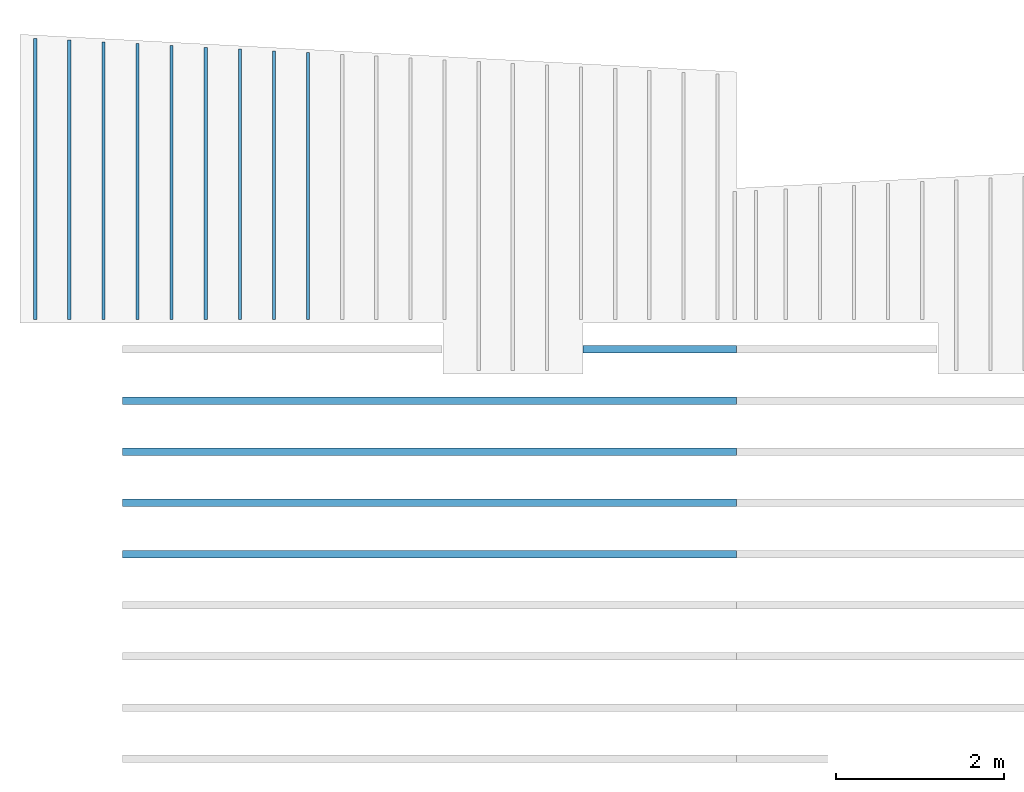
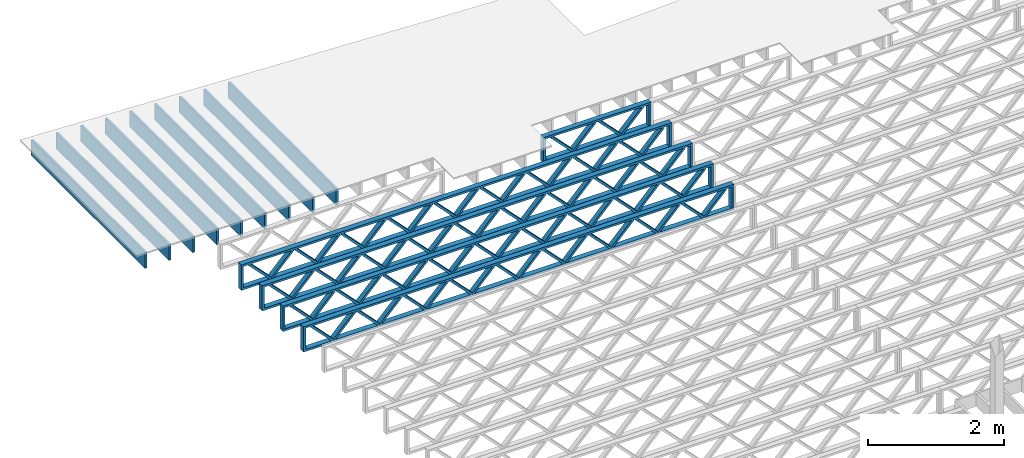
# One storey, part 3 of 12: 14 beams, 2 elements without a shape of their own.
"""IFC4 building model written with IfcOpenShell, lengths in feet."""

from ifc_helpers import new_model, entity, si_unit, converted_unit, derived_unit, direction, frame, frame_2d, origin, origin_2d_with_axis, place, context, subcontext, project, spatial, rectangle, extrude, source, transform, mapped, material, material_profile, profile_set, profile_usage, type_object, type_shapes, element, aggregate, save


model = new_model("IFC4")

# Units and contexts
model_context = context("Model", 3, precision=0.0001, world=origin(), true_north=direction((6.12303176911189e-17, 1.0)))
body_context = subcontext(model_context, "Body", "Model", "MODEL_VIEW")
ifc_project = project(units=[converted_unit("LENGTHUNIT", "FOOT", entity("IfcRatioMeasure", 0.3048), si_unit("LENGTHUNIT", "METRE"), dimensions=[1, 0, 0, 0, 0, 0, 0]), converted_unit("AREAUNIT", "SQUARE FOOT", entity("IfcRatioMeasure", 0.09290304), si_unit("AREAUNIT", "SQUARE_METRE"), dimensions=[2, 0, 0, 0, 0, 0, 0]), converted_unit("VOLUMEUNIT", "CUBIC FOOT", entity("IfcRatioMeasure", 0.028316846592), si_unit("VOLUMEUNIT", "CUBIC_METRE"), dimensions=[3, 0, 0, 0, 0, 0, 0]), converted_unit("PLANEANGLEUNIT", "DEGREE", entity("IfcRatioMeasure", 0.0174532925199433), si_unit("PLANEANGLEUNIT", "RADIAN"), dimensions=[0, 0, 0, 0, 0, 0, 0]), si_unit("MASSUNIT", "GRAM", prefix="KILO"), derived_unit("MASSDENSITYUNIT", [(si_unit("MASSUNIT", "GRAM", prefix="KILO"), 1), (si_unit("LENGTHUNIT", "METRE"), -3)]), derived_unit("MOMENTOFINERTIAUNIT", [(si_unit("LENGTHUNIT", "METRE"), 4)]), si_unit("TIMEUNIT", "SECOND"), si_unit("FREQUENCYUNIT", "HERTZ"), si_unit("THERMODYNAMICTEMPERATUREUNIT", "DEGREE_CELSIUS"), derived_unit("THERMALTRANSMITTANCEUNIT", [(si_unit("MASSUNIT", "GRAM", prefix="KILO"), 1), (si_unit("THERMODYNAMICTEMPERATUREUNIT", "KELVIN"), -1), (si_unit("TIMEUNIT", "SECOND"), -3)]), derived_unit("VOLUMETRICFLOWRATEUNIT", [(si_unit("LENGTHUNIT", "METRE"), 3), (si_unit("TIMEUNIT", "SECOND"), -1)]), si_unit("ELECTRICCURRENTUNIT", "AMPERE"), si_unit("ELECTRICVOLTAGEUNIT", "VOLT"), si_unit("POWERUNIT", "WATT"), si_unit("FORCEUNIT", "NEWTON"), si_unit("ILLUMINANCEUNIT", "LUX"), si_unit("LUMINOUSFLUXUNIT", "LUMEN"), si_unit("LUMINOUSINTENSITYUNIT", "CANDELA"), derived_unit("USERDEFINED", [(si_unit("MASSUNIT", "GRAM", prefix="KILO"), -1), (si_unit("LENGTHUNIT", "METRE"), -2), (si_unit("TIMEUNIT", "SECOND"), 3), (si_unit("LUMINOUSFLUXUNIT", "LUMEN"), 1)]), derived_unit("LINEARVELOCITYUNIT", [(si_unit("LENGTHUNIT", "METRE"), 1), (si_unit("TIMEUNIT", "SECOND"), -1)]), si_unit("PRESSUREUNIT", "PASCAL"), derived_unit("USERDEFINED", [(si_unit("LENGTHUNIT", "METRE"), -2), (si_unit("MASSUNIT", "GRAM", prefix="KILO"), 1), (si_unit("TIMEUNIT", "SECOND"), -2)]), derived_unit("LINEARFORCEUNIT", [(si_unit("MASSUNIT", "GRAM", prefix="KILO"), 1), (si_unit("LENGTHUNIT", "METRE"), 1), (si_unit("TIMEUNIT", "SECOND"), -2), (si_unit("LENGTHUNIT", "METRE"), -1)]), derived_unit("PLANARFORCEUNIT", [(si_unit("MASSUNIT", "GRAM", prefix="KILO"), 1), (si_unit("LENGTHUNIT", "METRE"), 1), (si_unit("TIMEUNIT", "SECOND"), -2), (si_unit("LENGTHUNIT", "METRE"), -2)])], contexts=[model_context])

# Site, building, storey
site_placement = place(None, origin())
site = spatial("IfcSite", under=ifc_project, at=site_placement, CompositionType="ELEMENT")
building_placement = place(site_placement, origin())
building = spatial("IfcBuilding", under=site, at=building_placement, CompositionType="ELEMENT")
storey_placement = place(building_placement, frame((0.0, 0.0, 21.46875)))
storey = spatial("IfcBuildingStorey", under=building, at=storey_placement, Name="3RD FLOOR", CompositionType="ELEMENT", Elevation=21.46875)

# Assembly, beams
assembly_1_placement = place(storey_placement, origin())
assembly_1 = element("IfcElementAssembly", 1, at=assembly_1_placement, inside=storey, Name="Structural Beam System:Structural Framing System", ObjectType="Structural Beam System:Structural Framing System", AssemblyPlace="NOTDEFINED", PredefinedType="BEAM_GRID")
ifc_material_1 = material(Name="WOOD TRUSS", Category="Materials")
ifc_material_profile_1 = material_profile(ifc_material_1, rectangle(XDim=1.73473973950632, YDim=0.125, at=frame_2d((-1.11022302462516e-16, 8.32667268468867e-17), x_axis=(1.0, 0.0))))
ifc_material_profile_2 = material_profile(ifc_material_1, rectangle(XDim=1.73473973950633, YDim=0.125, at=frame_2d((-1.11022302462516e-16, 8.32667268468867e-17), x_axis=(1.0, 0.0))))
ifc_material_profile_3 = material_profile(ifc_material_1, rectangle(XDim=1.73473973950632, YDim=0.125, at=frame_2d((-5.55111512312578e-17, 1.38777878078145e-16), x_axis=(1.0, 0.0))))
ifc_material_profile_4 = material_profile(ifc_material_1, rectangle(XDim=1.73473973950633, YDim=0.125, at=frame_2d((-1.11022302462516e-16, 8.32667268468867e-17), x_axis=(1.0, 0.0))))
ifc_material_profile_5 = material_profile(ifc_material_1, rectangle(XDim=1.73473973950632, YDim=0.125, at=frame_2d((-1.11022302462516e-16, 8.32667268468867e-17), x_axis=(1.0, 0.0))))
ifc_material_profile_6 = material_profile(ifc_material_1, rectangle(XDim=1.73473973950633, YDim=0.125, at=frame_2d((-2.77555756156289e-16, 3.05311331771918e-16), x_axis=(1.0, 0.0))))
ifc_material_profile_7 = material_profile(ifc_material_1, rectangle(XDim=1.73473973950632, YDim=0.124999999999999, at=frame_2d((-3.88578058618805e-16, -2.4980018054066e-16), x_axis=(1.0, 0.0))))
ifc_material_profile_8 = material_profile(ifc_material_1, rectangle(XDim=1.73473973950633, YDim=0.125, at=frame_2d((2.77555756156289e-16, -3.05311331771918e-16), x_axis=(1.0, 0.0))))
ifc_material_profile_9 = material_profile(ifc_material_1, rectangle(XDim=1.73473973950632, YDim=0.124999999999999, at=frame_2d((-1.11022302462516e-16, 8.32667268468867e-17), x_axis=(1.0, 0.0))))
ifc_material_profile_10 = material_profile(ifc_material_1, rectangle(XDim=1.73473973950633, YDim=0.125, at=origin_2d_with_axis()))
ifc_material_profile_11 = material_profile(ifc_material_1, rectangle(XDim=0.124999999999982, YDim=0.291666666666668, at=origin_2d_with_axis()))
ifc_material_profile_12 = material_profile(ifc_material_1, rectangle(XDim=0.124999999999932, YDim=0.291666666666664, at=origin_2d_with_axis()))
ifc_material_profile_13 = material_profile(ifc_material_1, rectangle(XDim=1.25000000000002, YDim=0.29166666666667, at=origin_2d_with_axis()))
ifc_material_profile_14 = material_profile(ifc_material_1, rectangle(XDim=1.25000000000004, YDim=0.291666666666667, at=origin_2d_with_axis()))
ifc_profile_set_1 = profile_set([ifc_material_profile_1, ifc_material_profile_2, ifc_material_profile_3, ifc_material_profile_4, ifc_material_profile_5, ifc_material_profile_6, ifc_material_profile_7, ifc_material_profile_8, ifc_material_profile_9, ifc_material_profile_10, ifc_material_profile_11, ifc_material_profile_12, ifc_material_profile_13, ifc_material_profile_14])
ifc_profile_usage_1 = profile_usage(ifc_profile_set_1, cardinal=8)
beam_type_1 = type_object("IfcBeamType", PredefinedType="BEAM", material=ifc_profile_set_1)
shared_shape_1 = source(origin(), body_context, "Body", "SweptSolid", [
    extrude(rectangle(XDim=1.73473973950632, YDim=0.125, at=frame_2d((0.0, 1.66533453693773e-16), x_axis=(1.0, 0.0))), frame((1.95847576769603, -0.145833333333334, 0.0), z_axis=(0.0, 1.0, 0.0), x_axis=(0.693383046997606, 0.0, 0.720569184836762)), (0.0, 0.0, 1.0), 0.291666666666667),
    extrude(rectangle(XDim=1.73473973950633, YDim=0.125, at=frame_2d((-5.55111512312578e-17, 8.32667268468867e-17), x_axis=(1.0, 0.0))), frame((0.708189894022761, -0.145833333333334, 0.0), z_axis=(0.0, 1.0, 0.0), x_axis=(0.69338304699761, 0.0, -0.720569184836758)), (0.0, 0.0, 1.0), 0.291666666666667),
    extrude(rectangle(XDim=1.73473973950632, YDim=0.125, at=frame_2d((0.0, 1.66533453693773e-16), x_axis=(1.0, 0.0))), frame((-0.708189894022106, -0.145833333333334, 0.0), z_axis=(0.0, 1.0, 0.0), x_axis=(0.693383046997606, 0.0, 0.720569184836762)), (0.0, 0.0, 1.0), 0.291666666666667),
    extrude(rectangle(XDim=1.73473973950633, YDim=0.125, at=frame_2d((-2.22044604925031e-16, 2.22044604925031e-16), x_axis=(1.0, 0.0))), frame((-1.95847576769538, -0.145833333333334, 0.0), z_axis=(0.0, 1.0, 0.0), x_axis=(0.69338304699761, 0.0, -0.720569184836758)), (0.0, 0.0, 1.0), 0.291666666666666),
    extrude(rectangle(XDim=0.124999999999982, YDim=0.291666666666668, at=origin_2d_with_axis()), frame((-2.99999949752565, 0.0, 0.687500000000054), z_axis=(1.0, 0.0, 0.0), x_axis=(0.0, 0.0, -1.0)), (0.0, 0.0, 1.0), 5.9999989950513),
    extrude(rectangle(XDim=0.124999999999932, YDim=0.291666666666664, at=origin_2d_with_axis()), frame((-2.99999949752544, 0.0, -0.687499999999984), z_axis=(1.0, 0.0, 0.0), x_axis=(0.0, 0.0, -1.0)), (0.0, 0.0, 1.0), 5.99999899505109),
    extrude(rectangle(XDim=1.25000000000002, YDim=0.29166666666667, at=origin_2d_with_axis()), frame((2.87499949752563, 0.0, 0.0), z_axis=(1.0, 0.0, 0.0), x_axis=(0.0, 0.0, -1.0)), (0.0, 0.0, 1.0), 0.12500000000002),
    extrude(rectangle(XDim=1.25000000000004, YDim=0.291666666666667, at=origin_2d_with_axis()), frame((-2.99999949752565, 0.0, 0.0), z_axis=(1.0, 0.0, 0.0), x_axis=(0.0, 0.0, -1.0)), (0.0, 0.0, 1.0), 0.125000000000023),
])
type_shapes(beam_type_1, [shared_shape_1])
beam_1_placement = place(assembly_1_placement, frame((-244.738160011261, 957.861934882651, -0.947916666657846)))
beam_1 = element("IfcBeam", 2, at=beam_1_placement, type_object=beam_type_1, material=ifc_profile_usage_1, PredefinedType="BEAM", context=body_context, shape_type="MappedRepresentation", body=[
    mapped(shared_shape_1, transform((0.0, 0.0, 0.0), scale=1.0)),
])
ifc_profile_usage_2 = profile_usage(ifc_profile_set_1, cardinal=8)
beam_type_2 = type_object("IfcBeamType", PredefinedType="BEAM", material=ifc_profile_set_1)
shared_shape_2 = source(origin(), body_context, "Body", "SweptSolid", [
    extrude(rectangle(XDim=1.73473973950632, YDim=0.124999999999999, at=frame_2d((5.55111512312578e-16, 7.21644966006352e-16), x_axis=(1.0, 0.0))), frame((8.37514585578398, -0.145833333333334, 0.0), z_axis=(0.0, 1.0, 0.0), x_axis=(0.693383046997606, 0.0, 0.720569184836762)), (0.0, 0.0, 1.0), 0.291666666666667),
    extrude(rectangle(XDim=1.73473973950633, YDim=0.125, at=origin_2d_with_axis()), frame((7.12485998211071, -0.145833333333334, 0.0), z_axis=(0.0, 1.0, 0.0), x_axis=(0.69338304699761, 0.0, -0.720569184836758)), (0.0, 0.0, 1.0), 0.291666666666666),
    extrude(rectangle(XDim=1.73473973950632, YDim=0.124999999999999, at=frame_2d((-1.11022302462516e-16, 8.32667268468867e-17), x_axis=(1.0, 0.0))), frame((5.79181154946831, -0.145833333333334, 0.0), z_axis=(0.0, 1.0, 0.0), x_axis=(0.693383046997606, 0.0, 0.720569184836762)), (0.0, 0.0, 1.0), 0.291666666666667),
    extrude(rectangle(XDim=1.73473973950633, YDim=0.125, at=origin_2d_with_axis()), frame((4.54152567579504, -0.145833333333334, 0.0), z_axis=(0.0, 1.0, 0.0), x_axis=(0.69338304699761, 0.0, -0.720569184836758)), (0.0, 0.0, 1.0), 0.291666666666666),
    extrude(rectangle(XDim=1.73473973950632, YDim=0.125, at=frame_2d((2.22044604925031e-16, 3.88578058618805e-16), x_axis=(1.0, 0.0))), frame((3.20847724315264, -0.145833333333334, 0.0), z_axis=(0.0, 1.0, 0.0), x_axis=(0.693383046997606, 0.0, 0.720569184836762)), (0.0, 0.0, 1.0), 0.291666666666667),
    extrude(rectangle(XDim=1.73473973950633, YDim=0.125, at=frame_2d((-1.11022302462516e-16, 8.32667268468867e-17), x_axis=(1.0, 0.0))), frame((1.95819136947937, -0.145833333333334, 0.0), z_axis=(0.0, 1.0, 0.0), x_axis=(0.69338304699761, 0.0, -0.720569184836758)), (0.0, 0.0, 1.0), 0.291666666666667),
    extrude(rectangle(XDim=1.73473973950632, YDim=0.125, at=frame_2d((-5.55111512312578e-17, 1.38777878078145e-16), x_axis=(1.0, 0.0))), frame((0.625142936836964, -0.145833333333334, 0.0), z_axis=(0.0, 1.0, 0.0), x_axis=(0.693383046997606, 0.0, 0.720569184836762)), (0.0, 0.0, 1.0), 0.291666666666667),
    extrude(rectangle(XDim=1.73473973950633, YDim=0.125, at=frame_2d((-1.11022302462516e-16, 8.32667268468867e-17), x_axis=(1.0, 0.0))), frame((-0.625142936836306, -0.145833333333334, 0.0), z_axis=(0.0, 1.0, 0.0), x_axis=(0.69338304699761, 0.0, -0.720569184836758)), (0.0, 0.0, 1.0), 0.291666666666667),
    extrude(rectangle(XDim=1.73473973950632, YDim=0.125, at=frame_2d((-1.11022302462516e-16, 8.32667268468867e-17), x_axis=(1.0, 0.0))), frame((-1.95819136947871, -0.145833333333334, 0.0), z_axis=(0.0, 1.0, 0.0), x_axis=(0.693383046997606, 0.0, 0.720569184836762)), (0.0, 0.0, 1.0), 0.291666666666667),
    extrude(rectangle(XDim=1.73473973950633, YDim=0.125, at=origin_2d_with_axis()), frame((-3.20847724315198, -0.145833333333334, 0.0), z_axis=(0.0, 1.0, 0.0), x_axis=(0.69338304699761, 0.0, -0.720569184836758)), (0.0, 0.0, 1.0), 0.291666666666667),
    extrude(rectangle(XDim=1.73473973950632, YDim=0.124999999999999, at=frame_2d((-1.11022302462516e-16, 8.32667268468867e-17), x_axis=(1.0, 0.0))), frame((-4.54152567579438, -0.145833333333334, 0.0), z_axis=(0.0, 1.0, 0.0), x_axis=(0.693383046997606, 0.0, 0.720569184836762)), (0.0, 0.0, 1.0), 0.291666666666667),
    extrude(rectangle(XDim=1.73473973950633, YDim=0.125, at=origin_2d_with_axis()), frame((-5.79181154946765, -0.145833333333334, 0.0), z_axis=(0.0, 1.0, 0.0), x_axis=(0.69338304699761, 0.0, -0.720569184836758)), (0.0, 0.0, 1.0), 0.291666666666666),
    extrude(rectangle(XDim=1.73473973950632, YDim=0.124999999999999, at=frame_2d((-1.11022302462516e-16, 8.32667268468867e-17), x_axis=(1.0, 0.0))), frame((-7.12485998211005, -0.145833333333334, 0.0), z_axis=(0.0, 1.0, 0.0), x_axis=(0.693383046997606, 0.0, 0.720569184836762)), (0.0, 0.0, 1.0), 0.291666666666667),
    extrude(rectangle(XDim=1.73473973950633, YDim=0.125, at=frame_2d((-2.77555756156289e-16, 3.05311331771918e-16), x_axis=(1.0, 0.0))), frame((-8.37514585578332, -0.145833333333334, 0.0), z_axis=(0.0, 1.0, 0.0), x_axis=(0.69338304699761, 0.0, -0.720569184836758)), (0.0, 0.0, 1.0), 0.291666666666666),
    extrude(rectangle(XDim=1.73473973950632, YDim=0.125, at=frame_2d((-7.21644966006352e-16, -5.55111512312578e-16), x_axis=(1.0, 0.0))), frame((10.9584801620997, -0.145833333333334, 0.0), z_axis=(0.0, 1.0, 0.0), x_axis=(0.693383046997606, 0.0, 0.720569184836762)), (0.0, 0.0, 1.0), 0.291666666666667),
    extrude(rectangle(XDim=1.73473973950633, YDim=0.125, at=origin_2d_with_axis()), frame((9.70819428842638, -0.145833333333334, 0.0), z_axis=(0.0, 1.0, 0.0), x_axis=(0.69338304699761, 0.0, -0.720569184836758)), (0.0, 0.0, 1.0), 0.291666666666666),
    extrude(rectangle(XDim=1.73473973950632, YDim=0.125, at=frame_2d((-5.55111512312578e-17, 8.32667268468867e-17), x_axis=(1.0, 0.0))), frame((-9.70819428842572, -0.145833333333334, 0.0), z_axis=(0.0, 1.0, 0.0), x_axis=(0.693383046997606, 0.0, 0.720569184836762)), (0.0, 0.0, 1.0), 0.291666666666667),
    extrude(rectangle(XDim=1.73473973950633, YDim=0.125, at=origin_2d_with_axis()), frame((-10.958480162099, -0.145833333333334, 0.0), z_axis=(0.0, 1.0, 0.0), x_axis=(0.69338304699761, 0.0, -0.720569184836758)), (0.0, 0.0, 1.0), 0.291666666666666),
    extrude(rectangle(XDim=0.124999999999982, YDim=0.291666666666668, at=origin_2d_with_axis()), frame((-12.0000038919293, 0.0, 0.687500000000054), z_axis=(1.0, 0.0, 0.0), x_axis=(0.0, 0.0, -1.0)), (0.0, 0.0, 1.0), 24.0000077838585),
    extrude(rectangle(XDim=0.124999999999932, YDim=0.291666666666664, at=origin_2d_with_axis()), frame((-12.0000038919291, 0.0, -0.687499999999984), z_axis=(1.0, 0.0, 0.0), x_axis=(0.0, 0.0, -1.0)), (0.0, 0.0, 1.0), 24.0000077838583),
    extrude(rectangle(XDim=1.25000000000002, YDim=0.29166666666667, at=origin_2d_with_axis()), frame((11.8750038919292, 0.0, 0.0), z_axis=(1.0, 0.0, 0.0), x_axis=(0.0, 0.0, -1.0)), (0.0, 0.0, 1.0), 0.12500000000002),
    extrude(rectangle(XDim=1.25000000000004, YDim=0.291666666666667, at=origin_2d_with_axis()), frame((-12.0000038919293, 0.0, 0.0), z_axis=(1.0, 0.0, 0.0), x_axis=(0.0, 0.0, -1.0)), (0.0, 0.0, 1.0), 0.125000000000023),
])
type_shapes(beam_type_2, [shared_shape_2])
beam_2_placement = place(assembly_1_placement, frame((-253.738164405664, 955.861934882651, -0.947916666657857)))
beam_2 = element("IfcBeam", 3, at=beam_2_placement, type_object=beam_type_2, material=ifc_profile_usage_2, PredefinedType="BEAM", context=body_context, shape_type="MappedRepresentation", body=[
    mapped(shared_shape_2, transform((0.0, 0.0, 0.0), scale=1.0)),
])
ifc_profile_usage_3 = profile_usage(ifc_profile_set_1, cardinal=8)
beam_type_3 = type_object("IfcBeamType", PredefinedType="BEAM", material=ifc_profile_set_1)
shared_shape_3 = source(origin(), body_context, "Body", "SweptSolid", [
    extrude(rectangle(XDim=1.73473973950632, YDim=0.124999999999999, at=frame_2d((5.55111512312578e-16, 7.21644966006352e-16), x_axis=(1.0, 0.0))), frame((8.37514585578398, -0.145833333333334, 0.0), z_axis=(0.0, 1.0, 0.0), x_axis=(0.693383046997606, 0.0, 0.720569184836762)), (0.0, 0.0, 1.0), 0.291666666666667),
    extrude(rectangle(XDim=1.73473973950633, YDim=0.125, at=origin_2d_with_axis()), frame((7.12485998211071, -0.145833333333334, 0.0), z_axis=(0.0, 1.0, 0.0), x_axis=(0.69338304699761, 0.0, -0.720569184836758)), (0.0, 0.0, 1.0), 0.291666666666666),
    extrude(rectangle(XDim=1.73473973950632, YDim=0.124999999999999, at=frame_2d((-1.11022302462516e-16, 8.32667268468867e-17), x_axis=(1.0, 0.0))), frame((5.79181154946831, -0.145833333333334, 0.0), z_axis=(0.0, 1.0, 0.0), x_axis=(0.693383046997606, 0.0, 0.720569184836762)), (0.0, 0.0, 1.0), 0.291666666666667),
    extrude(rectangle(XDim=1.73473973950633, YDim=0.125, at=origin_2d_with_axis()), frame((4.54152567579504, -0.145833333333334, 0.0), z_axis=(0.0, 1.0, 0.0), x_axis=(0.69338304699761, 0.0, -0.720569184836758)), (0.0, 0.0, 1.0), 0.291666666666666),
    extrude(rectangle(XDim=1.73473973950632, YDim=0.125, at=frame_2d((2.22044604925031e-16, 3.88578058618805e-16), x_axis=(1.0, 0.0))), frame((3.20847724315264, -0.145833333333334, 0.0), z_axis=(0.0, 1.0, 0.0), x_axis=(0.693383046997606, 0.0, 0.720569184836762)), (0.0, 0.0, 1.0), 0.291666666666667),
    extrude(rectangle(XDim=1.73473973950633, YDim=0.125, at=frame_2d((-1.11022302462516e-16, 8.32667268468867e-17), x_axis=(1.0, 0.0))), frame((1.95819136947937, -0.145833333333334, 0.0), z_axis=(0.0, 1.0, 0.0), x_axis=(0.69338304699761, 0.0, -0.720569184836758)), (0.0, 0.0, 1.0), 0.291666666666667),
    extrude(rectangle(XDim=1.73473973950632, YDim=0.125, at=frame_2d((-5.55111512312578e-17, 1.38777878078145e-16), x_axis=(1.0, 0.0))), frame((0.625142936836964, -0.145833333333334, 0.0), z_axis=(0.0, 1.0, 0.0), x_axis=(0.693383046997606, 0.0, 0.720569184836762)), (0.0, 0.0, 1.0), 0.291666666666667),
    extrude(rectangle(XDim=1.73473973950633, YDim=0.125, at=frame_2d((-1.11022302462516e-16, 8.32667268468867e-17), x_axis=(1.0, 0.0))), frame((-0.625142936836306, -0.145833333333334, 0.0), z_axis=(0.0, 1.0, 0.0), x_axis=(0.69338304699761, 0.0, -0.720569184836758)), (0.0, 0.0, 1.0), 0.291666666666667),
    extrude(rectangle(XDim=1.73473973950632, YDim=0.125, at=frame_2d((-1.11022302462516e-16, 8.32667268468867e-17), x_axis=(1.0, 0.0))), frame((-1.95819136947871, -0.145833333333334, 0.0), z_axis=(0.0, 1.0, 0.0), x_axis=(0.693383046997606, 0.0, 0.720569184836762)), (0.0, 0.0, 1.0), 0.291666666666667),
    extrude(rectangle(XDim=1.73473973950633, YDim=0.125, at=origin_2d_with_axis()), frame((-3.20847724315198, -0.145833333333334, 0.0), z_axis=(0.0, 1.0, 0.0), x_axis=(0.69338304699761, 0.0, -0.720569184836758)), (0.0, 0.0, 1.0), 0.291666666666667),
    extrude(rectangle(XDim=1.73473973950632, YDim=0.124999999999999, at=frame_2d((-1.11022302462516e-16, 8.32667268468867e-17), x_axis=(1.0, 0.0))), frame((-4.54152567579438, -0.145833333333334, 0.0), z_axis=(0.0, 1.0, 0.0), x_axis=(0.693383046997606, 0.0, 0.720569184836762)), (0.0, 0.0, 1.0), 0.291666666666667),
    extrude(rectangle(XDim=1.73473973950633, YDim=0.125, at=origin_2d_with_axis()), frame((-5.79181154946765, -0.145833333333334, 0.0), z_axis=(0.0, 1.0, 0.0), x_axis=(0.69338304699761, 0.0, -0.720569184836758)), (0.0, 0.0, 1.0), 0.291666666666666),
    extrude(rectangle(XDim=1.73473973950632, YDim=0.124999999999999, at=frame_2d((-1.11022302462516e-16, 8.32667268468867e-17), x_axis=(1.0, 0.0))), frame((-7.12485998211005, -0.145833333333334, 0.0), z_axis=(0.0, 1.0, 0.0), x_axis=(0.693383046997606, 0.0, 0.720569184836762)), (0.0, 0.0, 1.0), 0.291666666666667),
    extrude(rectangle(XDim=1.73473973950633, YDim=0.125, at=frame_2d((-2.77555756156289e-16, 3.05311331771918e-16), x_axis=(1.0, 0.0))), frame((-8.37514585578332, -0.145833333333334, 0.0), z_axis=(0.0, 1.0, 0.0), x_axis=(0.69338304699761, 0.0, -0.720569184836758)), (0.0, 0.0, 1.0), 0.291666666666666),
    extrude(rectangle(XDim=1.73473973950632, YDim=0.125, at=frame_2d((-7.21644966006352e-16, -5.55111512312578e-16), x_axis=(1.0, 0.0))), frame((10.9584801620997, -0.145833333333334, 0.0), z_axis=(0.0, 1.0, 0.0), x_axis=(0.693383046997606, 0.0, 0.720569184836762)), (0.0, 0.0, 1.0), 0.291666666666667),
    extrude(rectangle(XDim=1.73473973950633, YDim=0.125, at=origin_2d_with_axis()), frame((9.70819428842638, -0.145833333333334, 0.0), z_axis=(0.0, 1.0, 0.0), x_axis=(0.69338304699761, 0.0, -0.720569184836758)), (0.0, 0.0, 1.0), 0.291666666666666),
    extrude(rectangle(XDim=1.73473973950632, YDim=0.125, at=frame_2d((-5.55111512312578e-17, 8.32667268468867e-17), x_axis=(1.0, 0.0))), frame((-9.70819428842572, -0.145833333333334, 0.0), z_axis=(0.0, 1.0, 0.0), x_axis=(0.693383046997606, 0.0, 0.720569184836762)), (0.0, 0.0, 1.0), 0.291666666666667),
    extrude(rectangle(XDim=1.73473973950633, YDim=0.125, at=origin_2d_with_axis()), frame((-10.958480162099, -0.145833333333334, 0.0), z_axis=(0.0, 1.0, 0.0), x_axis=(0.69338304699761, 0.0, -0.720569184836758)), (0.0, 0.0, 1.0), 0.291666666666666),
    extrude(rectangle(XDim=0.124999999999982, YDim=0.291666666666668, at=origin_2d_with_axis()), frame((-12.0000038919293, 0.0, 0.687500000000054), z_axis=(1.0, 0.0, 0.0), x_axis=(0.0, 0.0, -1.0)), (0.0, 0.0, 1.0), 24.0000077838585),
    extrude(rectangle(XDim=0.124999999999932, YDim=0.291666666666664, at=origin_2d_with_axis()), frame((-12.0000038919291, 0.0, -0.687499999999984), z_axis=(1.0, 0.0, 0.0), x_axis=(0.0, 0.0, -1.0)), (0.0, 0.0, 1.0), 24.0000077838583),
    extrude(rectangle(XDim=1.25000000000002, YDim=0.29166666666667, at=origin_2d_with_axis()), frame((11.8750038919292, 0.0, 0.0), z_axis=(1.0, 0.0, 0.0), x_axis=(0.0, 0.0, -1.0)), (0.0, 0.0, 1.0), 0.12500000000002),
    extrude(rectangle(XDim=1.25000000000004, YDim=0.291666666666667, at=origin_2d_with_axis()), frame((-12.0000038919293, 0.0, 0.0), z_axis=(1.0, 0.0, 0.0), x_axis=(0.0, 0.0, -1.0)), (0.0, 0.0, 1.0), 0.125000000000023),
])
type_shapes(beam_type_3, [shared_shape_3])
beam_3_placement = place(assembly_1_placement, frame((-253.738164405664, 953.861934882651, -0.947916666657857)))
beam_3 = element("IfcBeam", 4, at=beam_3_placement, type_object=beam_type_3, material=ifc_profile_usage_3, PredefinedType="BEAM", context=body_context, shape_type="MappedRepresentation", body=[
    mapped(shared_shape_3, transform((0.0, 0.0, 0.0), scale=1.0)),
])
ifc_profile_usage_4 = profile_usage(ifc_profile_set_1, cardinal=8)
beam_4_placement = place(assembly_1_placement, frame((-253.738164405664, 951.861934882651, -0.947916666657857)))
beam_4 = element("IfcBeam", 5, at=beam_4_placement, type_object=beam_type_3, material=ifc_profile_usage_4, PredefinedType="BEAM", context=body_context, shape_type="MappedRepresentation", body=[
    mapped(shared_shape_3, transform((0.0, 0.0, 0.0), scale=1.0)),
])
ifc_profile_usage_5 = profile_usage(ifc_profile_set_1, cardinal=8)
beam_5_placement = place(assembly_1_placement, frame((-253.738164405664, 949.861934882651, -0.947916666657857)))
beam_5 = element("IfcBeam", 6, at=beam_5_placement, type_object=beam_type_3, material=ifc_profile_usage_5, PredefinedType="BEAM", context=body_context, shape_type="MappedRepresentation", body=[
    mapped(shared_shape_3, transform((0.0, 0.0, 0.0), scale=1.0)),
])
aggregate(assembly_1, [beam_1, beam_2, beam_3, beam_4, beam_5])

assembly_2_placement = place(storey_placement, origin())
assembly_2 = element("IfcElementAssembly", 7, at=assembly_2_placement, inside=storey, Name="Structural Beam System:Structural Framing System", ObjectType="Structural Beam System:Structural Framing System", AssemblyPlace="NOTDEFINED", PredefinedType="BEAM_GRID")
ifc_material_2 = material(Category="Materials")
ifc_material_profile_15 = material_profile(ifc_material_2, rectangle(XDim=0.9375, YDim=0.125000000000011, at=origin_2d_with_axis()))
ifc_profile_set_2 = profile_set([ifc_material_profile_15])
ifc_profile_usage_6 = profile_usage(ifc_profile_set_2, cardinal=8)
beam_type_4 = type_object("IfcBeamType", PredefinedType="BEAM", material=ifc_profile_set_2)
shared_shape_4 = source(origin(), body_context, "Body", "SweptSolid", [
    extrude(rectangle(XDim=0.9375, YDim=0.125000000000011, at=origin_2d_with_axis()), frame((-5.49546970597595, 0.0, 0.0), z_axis=(1.0, 0.0, 0.0), x_axis=(0.0, 0.0, -1.0)), (0.0, 0.0, 1.0), 10.9909394119519),
])
type_shapes(beam_type_4, [shared_shape_4])
beam_6_placement = place(assembly_2_placement, frame((-269.144289386034, 964.52407077504, -0.729166666666714), z_axis=(0.0, 0.0, 1.0), x_axis=(0.0, 1.0, 0.0)))
beam_6 = element("IfcBeam", 8, at=beam_6_placement, type_object=beam_type_4, material=ifc_profile_usage_6, PredefinedType="BEAM", context=body_context, shape_type="MappedRepresentation", body=[
    mapped(shared_shape_4, transform((0.0, 0.0, 0.0), scale=1.0)),
])
ifc_profile_usage_7 = profile_usage(ifc_profile_set_2, cardinal=8)
beam_type_5 = type_object("IfcBeamType", PredefinedType="BEAM", material=ifc_profile_set_2)
shared_shape_5 = source(origin(), body_context, "Body", "SweptSolid", [
    extrude(rectangle(XDim=0.9375, YDim=0.125000000000011, at=origin_2d_with_axis()), frame((-5.46053118645392, 0.0, 0.0), z_axis=(1.0, 0.0, 0.0), x_axis=(0.0, 0.0, -1.0)), (0.0, 0.0, 1.0), 10.9210623729078),
])
type_shapes(beam_type_5, [shared_shape_5])
beam_7_placement = place(assembly_2_placement, frame((-267.810956052701, 964.489132255518, -0.729166666666714), z_axis=(0.0, 0.0, 1.0), x_axis=(0.0, 1.0, 0.0)))
beam_7 = element("IfcBeam", 9, at=beam_7_placement, type_object=beam_type_5, material=ifc_profile_usage_7, PredefinedType="BEAM", context=body_context, shape_type="MappedRepresentation", body=[
    mapped(shared_shape_5, transform((0.0, 0.0, 0.0), scale=1.0)),
])
ifc_profile_usage_8 = profile_usage(ifc_profile_set_2, cardinal=8)
beam_type_6 = type_object("IfcBeamType", PredefinedType="BEAM", material=ifc_profile_set_2)
shared_shape_6 = source(origin(), body_context, "Body", "SweptSolid", [
    extrude(rectangle(XDim=0.9375, YDim=0.125000000000011, at=origin_2d_with_axis()), frame((-5.42559266693189, 0.0, 0.0), z_axis=(1.0, 0.0, 0.0), x_axis=(0.0, 0.0, -1.0)), (0.0, 0.0, 1.0), 10.8511853338638),
])
type_shapes(beam_type_6, [shared_shape_6])
beam_8_placement = place(assembly_2_placement, frame((-266.477622719368, 964.454193735996, -0.729166666666714), z_axis=(0.0, 0.0, 1.0), x_axis=(0.0, 1.0, 0.0)))
beam_8 = element("IfcBeam", 10, at=beam_8_placement, type_object=beam_type_6, material=ifc_profile_usage_8, PredefinedType="BEAM", context=body_context, shape_type="MappedRepresentation", body=[
    mapped(shared_shape_6, transform((0.0, 0.0, 0.0), scale=1.0)),
])
ifc_profile_usage_9 = profile_usage(ifc_profile_set_2, cardinal=8)
beam_type_7 = type_object("IfcBeamType", PredefinedType="BEAM", material=ifc_profile_set_2)
shared_shape_7 = source(origin(), body_context, "Body", "SweptSolid", [
    extrude(rectangle(XDim=0.9375, YDim=0.125000000000011, at=origin_2d_with_axis()), frame((-5.39065414740986, 0.0, 0.0), z_axis=(1.0, 0.0, 0.0), x_axis=(0.0, 0.0, -1.0)), (0.0, 0.0, 1.0), 10.7813082948197),
])
type_shapes(beam_type_7, [shared_shape_7])
beam_9_placement = place(assembly_2_placement, frame((-265.144289386034, 964.419255216474, -0.729166666666714), z_axis=(0.0, 0.0, 1.0), x_axis=(0.0, 1.0, 0.0)))
beam_9 = element("IfcBeam", 11, at=beam_9_placement, type_object=beam_type_7, material=ifc_profile_usage_9, PredefinedType="BEAM", context=body_context, shape_type="MappedRepresentation", body=[
    mapped(shared_shape_7, transform((0.0, 0.0, 0.0), scale=1.0)),
])
ifc_profile_usage_10 = profile_usage(ifc_profile_set_2, cardinal=8)
beam_type_8 = type_object("IfcBeamType", PredefinedType="BEAM", material=ifc_profile_set_2)
shared_shape_8 = source(origin(), body_context, "Body", "SweptSolid", [
    extrude(rectangle(XDim=0.9375, YDim=0.125000000000011, at=origin_2d_with_axis()), frame((-5.35571562788789, 0.0, 0.0), z_axis=(1.0, 0.0, 0.0), x_axis=(0.0, 0.0, -1.0)), (0.0, 0.0, 1.0), 10.7114312557758),
])
type_shapes(beam_type_8, [shared_shape_8])
beam_10_placement = place(assembly_2_placement, frame((-263.810956052701, 964.384316696952, -0.729166666666714), z_axis=(0.0, 0.0, 1.0), x_axis=(0.0, 1.0, 0.0)))
beam_10 = element("IfcBeam", 12, at=beam_10_placement, type_object=beam_type_8, material=ifc_profile_usage_10, PredefinedType="BEAM", context=body_context, shape_type="MappedRepresentation", body=[
    mapped(shared_shape_8, transform((0.0, 0.0, 0.0), scale=1.0)),
])
ifc_profile_usage_11 = profile_usage(ifc_profile_set_2, cardinal=8)
beam_type_9 = type_object("IfcBeamType", PredefinedType="BEAM", material=ifc_profile_set_2)
shared_shape_9 = source(origin(), body_context, "Body", "SweptSolid", [
    extrude(rectangle(XDim=0.9375, YDim=0.125000000000011, at=origin_2d_with_axis()), frame((-5.32077710836586, 0.0, 0.0), z_axis=(1.0, 0.0, 0.0), x_axis=(0.0, 0.0, -1.0)), (0.0, 0.0, 1.0), 10.6415542167317),
])
type_shapes(beam_type_9, [shared_shape_9])
beam_11_placement = place(assembly_2_placement, frame((-262.477622719368, 964.34937817743, -0.729166666666714), z_axis=(0.0, 0.0, 1.0), x_axis=(0.0, 1.0, 0.0)))
beam_11 = element("IfcBeam", 13, at=beam_11_placement, type_object=beam_type_9, material=ifc_profile_usage_11, PredefinedType="BEAM", context=body_context, shape_type="MappedRepresentation", body=[
    mapped(shared_shape_9, transform((0.0, 0.0, 0.0), scale=1.0)),
])
ifc_profile_usage_12 = profile_usage(ifc_profile_set_2, cardinal=8)
beam_type_10 = type_object("IfcBeamType", PredefinedType="BEAM", material=ifc_profile_set_2)
shared_shape_10 = source(origin(), body_context, "Body", "SweptSolid", [
    extrude(rectangle(XDim=0.9375, YDim=0.125000000000011, at=origin_2d_with_axis()), frame((-5.28583858884383, 0.0, 0.0), z_axis=(1.0, 0.0, 0.0), x_axis=(0.0, 0.0, -1.0)), (0.0, 0.0, 1.0), 10.5716771776877),
])
type_shapes(beam_type_10, [shared_shape_10])
beam_12_placement = place(assembly_2_placement, frame((-261.144289386034, 964.314439657908, -0.729166666666714), z_axis=(0.0, 0.0, 1.0), x_axis=(0.0, 1.0, 0.0)))
beam_12 = element("IfcBeam", 14, at=beam_12_placement, type_object=beam_type_10, material=ifc_profile_usage_12, PredefinedType="BEAM", context=body_context, shape_type="MappedRepresentation", body=[
    mapped(shared_shape_10, transform((0.0, 0.0, 0.0), scale=1.0)),
])
ifc_profile_usage_13 = profile_usage(ifc_profile_set_2, cardinal=8)
beam_type_11 = type_object("IfcBeamType", PredefinedType="BEAM", material=ifc_profile_set_2)
shared_shape_11 = source(origin(), body_context, "Body", "SweptSolid", [
    extrude(rectangle(XDim=0.9375, YDim=0.125000000000011, at=origin_2d_with_axis()), frame((-5.2509000693218, 0.0, 0.0), z_axis=(1.0, 0.0, 0.0), x_axis=(0.0, 0.0, -1.0)), (0.0, 0.0, 1.0), 10.5018001386436),
])
type_shapes(beam_type_11, [shared_shape_11])
beam_13_placement = place(assembly_2_placement, frame((-259.810956052701, 964.279501138386, -0.729166666666714), z_axis=(0.0, 0.0, 1.0), x_axis=(0.0, 1.0, 0.0)))
beam_13 = element("IfcBeam", 15, at=beam_13_placement, type_object=beam_type_11, material=ifc_profile_usage_13, PredefinedType="BEAM", context=body_context, shape_type="MappedRepresentation", body=[
    mapped(shared_shape_11, transform((0.0, 0.0, 0.0), scale=1.0)),
])
ifc_profile_usage_14 = profile_usage(ifc_profile_set_2, cardinal=8)
beam_type_12 = type_object("IfcBeamType", PredefinedType="BEAM", material=ifc_profile_set_2)
shared_shape_12 = source(origin(), body_context, "Body", "SweptSolid", [
    extrude(rectangle(XDim=0.9375, YDim=0.125000000000011, at=origin_2d_with_axis()), frame((-5.21596154979977, 0.0, 0.0), z_axis=(1.0, 0.0, 0.0), x_axis=(0.0, 0.0, -1.0)), (0.0, 0.0, 1.0), 10.4319230995995),
])
type_shapes(beam_type_12, [shared_shape_12])
beam_14_placement = place(assembly_2_placement, frame((-258.477622719368, 964.244562618864, -0.729166666666714), z_axis=(0.0, 0.0, 1.0), x_axis=(0.0, 1.0, 0.0)))
beam_14 = element("IfcBeam", 16, at=beam_14_placement, type_object=beam_type_12, material=ifc_profile_usage_14, PredefinedType="BEAM", context=body_context, shape_type="MappedRepresentation", body=[
    mapped(shared_shape_12, transform((0.0, 0.0, 0.0), scale=1.0)),
])
aggregate(assembly_2, [beam_6, beam_7, beam_8, beam_9, beam_10, beam_11, beam_12, beam_13, beam_14])

save(model, "model.ifc")
